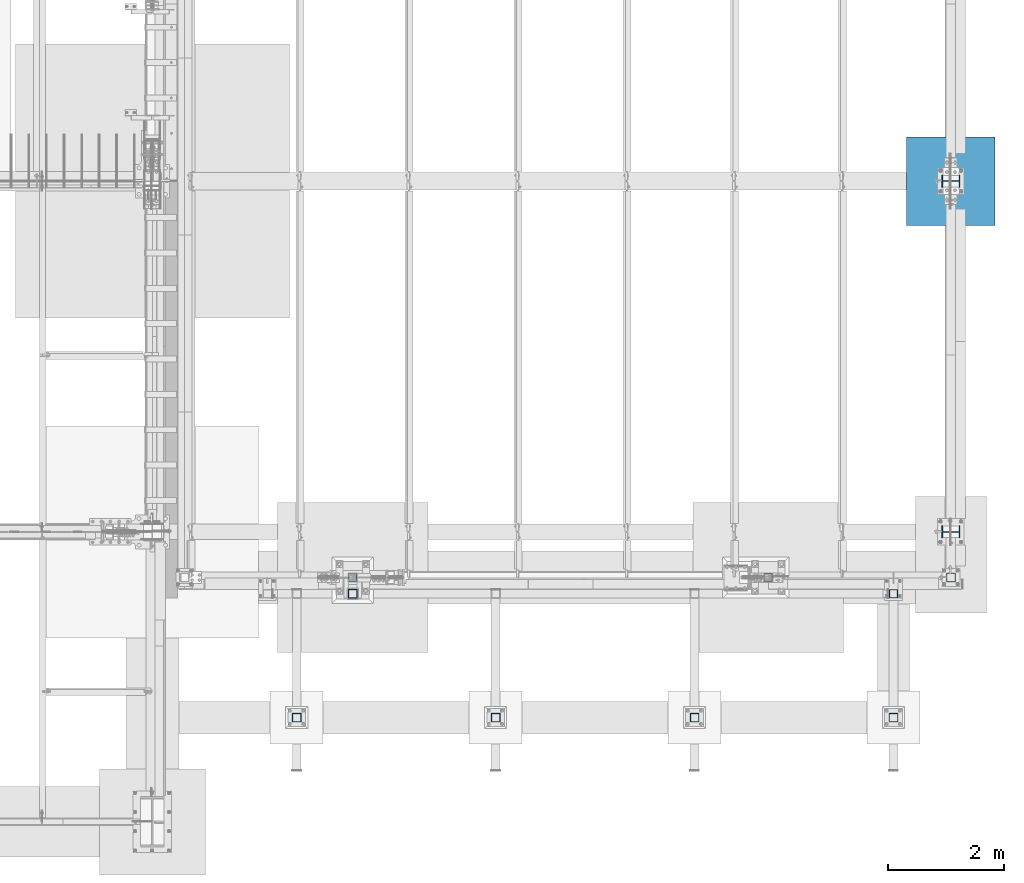
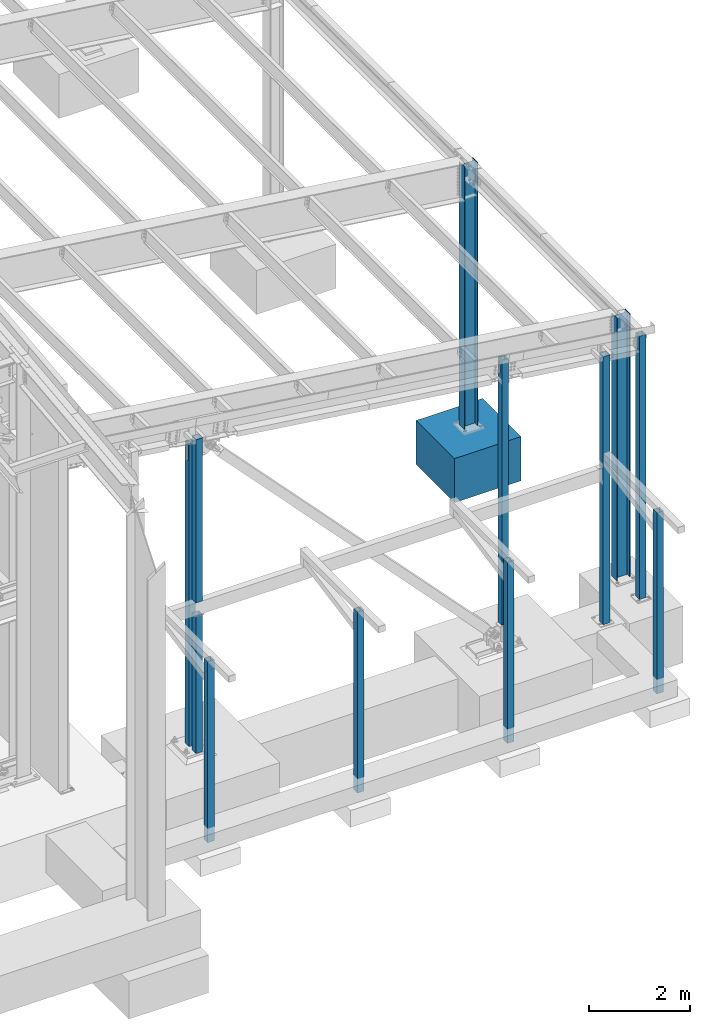
# One storey, part 360 of 1179: 13 columns, 13 elements without a shape of their own.
"""IFC2X3 building model written with IfcOpenShell, lengths in millimetres."""

from ifc_helpers import new_model, si_unit, frame, origin_with_axes, place, context, subcontext, project, spatial, faceted_brep, material, type_object, element, aggregate, save


model = new_model("IFC2X3")

# Units and contexts
model_context = context("Model", 3, precision=1e-05, world=origin_with_axes())
body_context = subcontext(model_context, "Body", "Model", "MODEL_VIEW")
ifc_project = project(units=[si_unit("LENGTHUNIT", "METRE", prefix="MILLI"), si_unit("AREAUNIT", "SQUARE_METRE"), si_unit("VOLUMEUNIT", "CUBIC_METRE"), si_unit("MASSUNIT", "GRAM", prefix="KILO"), si_unit("TIMEUNIT", "SECOND"), si_unit("PLANEANGLEUNIT", "RADIAN"), si_unit("SOLIDANGLEUNIT", "STERADIAN"), si_unit("THERMODYNAMICTEMPERATUREUNIT", "DEGREE_CELSIUS"), si_unit("LUMINOUSINTENSITYUNIT", "LUMEN")], contexts=[model_context])

# Site, building, storey
site_placement = place(None, origin_with_axes())
site = spatial("IfcSite", under=ifc_project, at=site_placement, CompositionType="ELEMENT")
building_placement = place(site_placement, origin_with_axes())
building = spatial("IfcBuilding", under=site, at=building_placement, Name="Undefined", CompositionType="ELEMENT")
storey_placement = place(building_placement, origin_with_axes())
storey = spatial("IfcBuildingStorey", under=building, at=storey_placement, Name="Undefined", CompositionType="ELEMENT", Elevation=0.0)

# Assembly, column
assembly_1_placement = place(storey_placement, origin_with_axes())
assembly_1 = element("IfcElementAssembly", 1, at=assembly_1_placement, inside=storey, Name="COLUMN", AssemblyPlace="NOTDEFINED", PredefinedType="RIGID_FRAME")
ifc_material_1 = material()
column_type_1 = type_object("IfcColumnType", Name="HSS6X6X3/8", PredefinedType="NOTDEFINED")
column_1_placement = place(assembly_1_placement, frame((38074.6, 4648.2, -355.599999999999), z_axis=(0.0, 1.0, 0.0), x_axis=(0.0, 0.0, 1.0)))
column_1 = element("IfcColumn", 2, at=column_1_placement, type_object=column_type_1, material=ifc_material_1, Name="COLUMN", ObjectType="HSS6X6X3/8", context=body_context, shape_type="Brep", body=[
    faceted_brep([(76.2000000000008, 66.675000000112, -66.6749999999902), (76.2000000000008, -66.6750000001084, -66.6750000000175), (6446.8375, -66.6750000000029, -66.6750000000002), (6446.8375, 66.6750000000029, -66.6750000000002), (76.2000000000008, -66.6750000001011, 66.674999999992), (6446.8375, -66.6750000000029, 66.6750000000002), (76.2000000000008, 66.6750000001193, 66.6750000000193), (6446.8375, 66.6750000000029, 66.6750000000002), (76.2000000000008, 76.2000000001281, -76.1999999999898), (76.2000000000008, 76.2000000001317, 76.2000000000216), (6446.8375, 76.1999999999971, 76.1999999999998), (6446.8375, 76.1999999999971, -76.1999999999998), (76.2000000000008, -76.2000000001171, 76.1999999999916), (6446.8375, -76.1999999999971, 76.1999999999998), (76.2000000000008, -76.2000000001208, -76.2000000000198), (6446.8375, -76.1999999999971, -76.1999999999998)], [[[0, 1, 2, 3]], [[1, 4, 5, 2]], [[4, 6, 7, 5]], [[6, 0, 3, 7]], [[8, 9, 10, 11]], [[9, 12, 13, 10]], [[12, 14, 15, 13]], [[14, 8, 11, 15]], [[13, 15, 11, 10], [5, 7, 3, 2]], [[14, 12, 9, 8], [6, 4, 1, 0]]]),
])
aggregate(assembly_1, [column_1])

assembly_2_placement = place(storey_placement, origin_with_axes())
assembly_2 = element("IfcElementAssembly", 3, at=assembly_2_placement, inside=storey, Name="COLUMN", AssemblyPlace="NOTDEFINED", PredefinedType="RIGID_FRAME")
column_type_2 = type_object("IfcColumnType", Name="HSS6X6X5/8", PredefinedType="NOTDEFINED")
column_2_placement = place(assembly_2_placement, frame((34925.0, 4648.2, 495.299974039363), z_axis=(0.0, 1.0, 0.0), x_axis=(0.0, 0.0, 1.0)))
column_2 = element("IfcColumn", 4, at=column_2_placement, type_object=column_type_2, material=ifc_material_1, Name="COLUMN", ObjectType="HSS6X6X5/8", context=body_context, shape_type="Brep", body=[
    faceted_brep([(5747.63958632009, -76.2000000000407, 5.85754753591027), (5747.60831617678, -76.2000000000407, -3.82465809047153), (5747.63958632009, -60.3249999999971, 5.85754753591027), (6052.92287423471, -60.3249999999971, 5.55625000000236), (5749.15431132124, -60.3249999999971, 5.55625000000236), (6053.99631617678, -76.2000000000407, -3.82465809047153), (6053.98303151881, -60.3249999999971, 5.76712839517677), (6053.99631617678, -76.2000000000407, 5.70034190952811), (6118.01037424087, -76.1999999999971, 76.1999999999998), (6097.4321702663, 76.1999999999971, 76.1999999999998), (-297.364801174595, 76.1999999999971, 76.1999999999998), (-297.364801177734, -76.2000000009066, 76.2000000009066), (-306.53024097503, 60.3249999999971, 60.3249999999998), (-306.53024097503, -60.3249999999971, 60.3249999999998), (6099.57573318032, 60.3249999999971, 60.3249999999998), (6115.86681132685, -60.3249999999971, 60.3249999999998), (6115.86681132685, -60.3249999999971, -60.3249999999998), (6099.57573318032, 60.3249999999971, -60.3249999999998), (-306.53024097503, 60.3249999999971, -60.3249999999998), (-306.53024097503, -60.3249999999971, -60.3249999999998), (6118.01037424087, -76.1999999999971, -76.1999999999998), (6097.4321702663, 76.1999999999971, -76.1999999999998), (-297.364801178257, -76.1999999999971, -76.1999999999998), (-297.364801178257, 76.1999999999971, -76.1999999999998), (5727.68212052118, 76.1999999999971, 6.16045621069406), (5727.68212052118, 60.3249999999971, 6.16045621069406), (5729.99527131832, 60.3249999999971, 5.70034190952811), (5729.99527131832, 76.1999999999971, 5.70034190952811), (5725.10701018991, 76.1999999999971, 7.88108992433445), (5725.10701018991, 60.3249999999971, 7.88108992433445), (5723.38637647627, 76.1999999999971, 10.456200255604), (5723.38637647627, 60.3249999999971, 10.456200255604), (5722.78217026557, 76.1999999999971, 13.4937500000024), (5722.78217026557, 60.3249999999971, 13.4937500000024), (5722.78217026557, 76.1999999999971, 26.1937500000031), (5722.78217026557, 60.3249999999971, 26.1937500000031), (5723.38637647627, 76.1999999999971, 29.2312997444014), (5723.38637647627, 60.3249999999971, 29.2312997444014), (5725.10701018991, 76.1999999999971, 31.806410075671), (5725.10701018991, 60.3249999999971, 31.806410075671), (5727.68212052118, 76.1999999999971, 33.5270437893114), (5727.68212052118, 60.3249999999971, 33.5270437893114), (5729.72700903751, 76.1999999999971, 33.9337974051232), (5729.72700903751, 60.3249999999971, 33.9337974051232), (5729.72700903751, 76.2000000001353, 43.0992329262926), (6036.11500903751, 76.2000000001353, 43.0992329262926), (6036.09087448646, 60.3249999999971, 33.8124648234862), (6034.48823317905, 60.3249999999971, 34.1312500000031), (5730.71967026557, 60.3249999999971, 34.1312500000031), (6036.09087448646, 76.1999999999971, 33.8124648234862), (6037.52578292345, 76.1999999999971, 33.5270437893114), (6037.52578292345, 60.3249999999971, 33.5270437893114), (6040.10089325472, 76.1999999999971, 31.806410075671), (6040.10089325472, 60.3249999999971, 31.806410075671), (6041.82152696836, 76.1999999999971, 29.2312997444014), (6041.82152696836, 60.3249999999971, 29.2312997444014), (6042.42573317905, 76.1999999999971, 26.1937500000031), (6042.42573317905, 60.3249999999971, 26.1937500000031), (6042.42573317905, 76.1999999999971, 13.4937500000024), (6042.42573317905, 60.3249999999971, 13.4937500000024), (6041.82152696836, 76.1999999999971, 10.456200255604), (6041.82152696836, 60.3249999999971, 10.456200255604), (6040.10089325472, 76.1999999999971, 7.88108992433445), (6040.10089325472, 60.3249999999971, 7.88108992433445), (6037.52578292345, 76.1999999999971, 6.16045621069406), (6037.52578292345, 60.3249999999971, 6.16045621069406), (6036.33871651704, 76.1999999999971, 5.92433402155893), (6036.38327131832, 60.3249999999971, 5.70034190952811), (6036.38327131832, 76.1999999999971, -3.82465809047153), (5729.99527131832, 76.1999999999971, -3.82465809047153), (5730.71967026557, 60.3249999999971, 5.55625000000236), (6034.48823317905, 60.3249999999971, 5.55625000000236), (5746.11676157684, -76.200000000048, 6.16045621069406), (5746.11676157684, -60.3249999999971, 6.16045621069406), (5743.54165124557, -60.3249999999971, 7.88108992433445), (5743.54165124557, -76.200000000048, 7.88108992433445), (5741.82101753193, -60.3249999999971, 10.456200255604), (5741.82101753193, -76.2000000000553, 10.456200255604), (5741.21681132124, -60.3249999999971, 13.4937500000024), (5741.21681132124, -76.2000000000698, 13.4937500000024), (5741.21681132124, -60.3249999999971, 26.1937500000031), (5741.21681132124, -76.2000000001062, 26.1937500000031), (5741.82101753193, -60.3249999999971, 29.2312997444014), (5741.82101753193, -76.2000000001135, 29.2312997444014), (5743.54165124557, -60.3249999999971, 31.806410075671), (5743.54165124557, -76.2000000001208, 31.806410075671), (5746.11676157684, -60.3249999999971, 33.5270437893114), (5746.11676157684, -76.2000000001281, 33.5270437893114), (5747.5894509322, -60.3249999999971, 33.8199799154008), (5747.5894509322, -76.2000000001281, 33.8199799154008), (5747.56681122587, -76.2000000001208, 43.0992329262926), (5749.15431132124, -60.3249999999971, 34.1312500000031), (6052.92287423471, -60.3249999999971, 34.1312500000031), (6053.95331638115, -60.3249999999971, 33.9262823132085), (6053.95481122587, -76.2000000001208, 43.0992329262926), (6053.95331638115, -76.2000000001062, 33.9262823132085), (6055.96042397911, -60.3249999999971, 33.5270437893114), (6055.96042397911, -76.2000000001062, 33.5270437893114), (6058.53553431038, -60.3249999999971, 31.806410075671), (6058.53553431038, -76.200000000099, 31.806410075671), (6060.25616802402, -60.3249999999971, 29.2312997444014), (6060.25616802402, -76.2000000000917, 29.2312997444014), (6060.86037423471, -60.3249999999971, 26.1937500000031), (6060.86037423471, -76.2000000000844, 26.1937500000031), (6060.86037423471, -60.3249999999971, 13.4937500000024), (6060.86037423471, -76.2000000000407, 13.4937500000024), (6060.25616802402, -60.3249999999971, 10.456200255604), (6060.25616802402, -76.2000000000335, 10.456200255604), (6058.53553431038, -60.3249999999971, 7.88108992433445), (6058.53553431038, -76.2000000000262, 7.88108992433445), (6055.96042397911, -60.3249999999971, 6.16045621069406), (6055.96042397911, -76.2000000000262, 6.16045621069406)], [[[0, 1, 2]], [[3, 4, 2, 1, 5, 6]], [[7, 6, 5]], [[8, 9, 10, 11]], [[10, 12, 13, 11]], [[14, 15, 13, 12]], [[16, 17, 18, 19]], [[8, 20, 21, 9], [15, 14, 17, 16]], [[21, 20, 22, 23]], [[24, 25, 26, 27]], [[25, 24, 28, 29]], [[29, 28, 30, 31]], [[31, 30, 32, 33]], [[33, 32, 34, 35]], [[35, 34, 36, 37]], [[37, 36, 38, 39]], [[39, 38, 40, 41]], [[41, 40, 42, 43]], [[44, 43, 42]], [[45, 46, 47, 48, 43, 44]], [[49, 46, 45]], [[50, 51, 46, 49]], [[51, 50, 52, 53]], [[53, 52, 54, 55]], [[55, 54, 56, 57]], [[57, 56, 58, 59]], [[59, 58, 60, 61]], [[61, 60, 62, 63]], [[63, 62, 64, 65]], [[65, 64, 66, 67]], [[66, 68, 67]], [[9, 21, 23, 10], [64, 62, 60, 58, 56, 54, 52, 50, 49, 45, 44, 42, 40, 38, 36, 34, 32, 30, 28, 24, 27, 69, 68, 66]], [[26, 69, 27]], [[67, 68, 69, 26, 70, 71]], [[17, 14, 12, 18], [70, 26, 25, 29, 31, 33, 35, 37, 39, 41, 43, 48, 47, 46, 51, 53, 55, 57, 59, 61, 63, 65, 67, 71]], [[10, 23, 18, 12]], [[22, 19, 18, 23]], [[11, 13, 19, 22]], [[72, 73, 74, 75]], [[75, 74, 76, 77]], [[77, 76, 78, 79]], [[79, 78, 80, 81]], [[81, 80, 82, 83]], [[83, 82, 84, 85]], [[85, 84, 86, 87]], [[87, 86, 88, 89]], [[89, 88, 90]], [[90, 88, 91, 92, 93, 94]], [[94, 93, 95]], [[96, 97, 95, 93]], [[97, 96, 98, 99]], [[99, 98, 100, 101]], [[101, 100, 102, 103]], [[103, 102, 104, 105]], [[105, 104, 106, 107]], [[107, 106, 108, 109]], [[109, 108, 110, 111]], [[20, 8, 11, 22], [1, 0, 72, 75, 77, 79, 81, 83, 85, 87, 89, 90, 94, 95, 97, 99, 101, 103, 105, 107, 109, 111, 7, 5]], [[73, 72, 0, 2]], [[15, 16, 19, 13], [110, 108, 106, 104, 102, 100, 98, 96, 93, 92, 91, 88, 86, 84, 82, 80, 78, 76, 74, 73, 2, 4, 3, 6]], [[111, 110, 6, 7]]]),
])
aggregate(assembly_2, [column_2])

assembly_3_placement = place(storey_placement, origin_with_axes())
assembly_3 = element("IfcElementAssembly", 5, at=assembly_3_placement, inside=storey, Name="COLUMN", AssemblyPlace="NOTDEFINED", PredefinedType="RIGID_FRAME")
column_3_placement = place(assembly_3_placement, frame((27762.2, 4648.2, -355.599999999999), z_axis=(0.0, 1.0, 0.0), x_axis=(0.0, 0.0, 1.0)))
column_3 = element("IfcColumn", 6, at=column_3_placement, type_object=column_type_2, material=ifc_material_1, Name="COLUMN", ObjectType="HSS6X6X5/8", context=body_context, shape_type="Brep", body=[
    faceted_brep([(7017.90605595571, -76.2000000000007, 19.0500000000029), (7017.90605595571, -60.3250000000007, 19.0500000000029), (7017.90605595571, -76.2000000000007, 28.215435902579), (7453.45682125332, -60.3250000000044, 19.0500003814714), (7446.45897397895, -76.2000000000007, 28.215435902579), (127.0, -76.2000000000007, -76.1999999999998), (127.0, 76.2000000000007, -76.1999999999998), (7425.89405519277, 76.2000000000007, -76.1999999999998), (7446.38942084956, -76.2000000000007, -76.1999999999998), (7425.89405519277, 76.2000000000007, 76.1999999999998), (7437.16574310679, 60.3250000000007, 60.3249999999998), (7437.16574310679, 60.3250000000116, 19.0500000000029), (7425.89405519277, 76.2000000000007, 28.2154355211105), (127.0, 60.3250000000007, 60.3249999999998), (127.0, 60.3250000000007, -60.3249999999998), (7437.16574310679, 60.3250000000007, -60.3249999999998), (7437.14646512411, 60.3250000000116, -19.0499999999956), (7017.90605477555, 60.3251050701656, -19.0499999999956), (7017.59729324514, 60.3250000000007, -19.0499999999956), (7013.95223369785, 60.3250000000007, -18.324952576203), (7010.86210142408, 60.3250000000007, -16.2601922025278), (7008.79734105041, 60.3250000000007, -13.1700599287606), (7008.07229362661, 60.3250000000007, -9.52500038146536), (7008.07229362661, 60.3250000000007, 9.52500038147264), (7008.79734105041, 60.3250000000007, 13.1700599287678), (7010.86210142408, 60.3250000000007, 16.2601922025351), (7013.95223369785, 60.3250000000007, 18.3249525762103), (7017.59729324514, 60.3250000000007, 19.0500000000029), (7017.9060548113, 60.3250000000007, 19.0500000000029), (7017.59729324514, 76.2000000000007, -19.0499999999956), (7017.9060548113, 76.2000000000007, -19.0499999999956), (7013.95223369785, 76.2000000000007, -18.324952576203), (7010.86210142408, 76.2000000000007, -16.2601922025278), (7008.79734105041, 76.2000000000007, -13.1700599287606), (7008.07229362661, 76.2000000000007, -9.52500038146536), (7008.07229362661, 76.2000000000007, 9.52500038147264), (7008.79734105041, 76.2000000000007, 13.1700599287678), (7010.86210142408, 76.2000000000007, 16.2601922025351), (7013.95223369785, 76.2000000000007, 18.3249525762103), (7017.59729324514, 76.2000000000007, 19.0500000000029), (7017.9060548113, 76.2000000000007, 19.0500000000029), (7017.9060548113, 76.200000000008, 28.2154355211105), (7017.9060548113, 76.200000000008, -28.2154355211032), (7425.89405519277, 76.2000000000007, -28.2154355211032), (127.0, 76.2000000000007, 76.1999999999998), (7013.95223369785, -76.2000000000007, 18.3249525762103), (7013.95223369785, -60.3250000000007, 18.3249525762103), (7017.59729324514, -60.3250000000007, 19.0500000000029), (7017.59729324514, -76.2000000000007, 19.0500000000029), (7010.86210142408, -76.2000000000007, 16.2601922025351), (7010.86210142408, -60.3250000000007, 16.2601922025351), (7008.79734105041, -76.2000000000007, 13.1700599287678), (7008.79734105041, -60.3250000000007, 13.1700599287678), (7008.07229362661, -76.2000000000007, 9.52500038147264), (7008.07229362661, -60.3250000000007, 9.52500038147264), (7008.07229362661, -76.2000000000007, -9.52500038146536), (7008.07229362661, -60.3250000000007, -9.52500038146536), (7008.79734105041, -76.2000000000007, -13.1700599287606), (7008.79734105041, -60.3250000000007, -13.1700599287606), (7010.86210142408, -76.2000000000007, -16.2601922025278), (7010.86210142408, -60.3250000000007, -16.2601922025278), (7013.95223369785, -76.2000000000007, -18.324952576203), (7013.95223369785, -60.3250000000007, -18.324952576203), (7017.59729324514, -76.2000000000007, -19.0499999999956), (7017.59729324514, -60.3250000000007, -19.0499999999956), (7017.90605595571, -76.2000000000007, -19.0499999999956), (7017.90605592259, -60.3251011342254, -19.0499999999956), (7017.90605595571, -76.2000000000007, -28.2154359025726), (7453.47609923807, -60.3250000000044, -19.050000381465), (7446.45897396538, -76.2000000000007, -28.2154359025726), (7453.45682125332, -60.3250000000007, -60.3249999999998), (127.0, -60.3250000000007, -60.3249999999998), (127.0, -76.2000000000007, 76.1999999999998), (127.0, -60.3250000000007, 60.3249999999998), (7446.38942093416, -76.2000000000007, 76.1999999999998), (7453.47609923807, -60.4677707066257, 60.3249999999998)], [[[0, 1, 2]], [[3, 4, 2, 1]], [[5, 6, 7, 8]], [[9, 10, 11, 12]], [[10, 13, 14, 15, 16, 17, 18, 19, 20, 21, 22, 23, 24, 25, 26, 27, 28, 11]], [[29, 18, 17, 30]], [[18, 29, 31, 19]], [[19, 31, 32, 20]], [[20, 32, 33, 21]], [[21, 33, 34, 22]], [[22, 34, 35, 23]], [[23, 35, 36, 24]], [[24, 36, 37, 25]], [[25, 37, 38, 26]], [[26, 38, 39, 27]], [[27, 39, 40, 28]], [[41, 28, 40]], [[11, 28, 41, 12]], [[40, 39, 38, 37, 36, 35, 34, 33, 32, 31, 29, 30, 42, 43, 7, 6, 44, 9, 12, 41]], [[17, 42, 30]], [[16, 43, 42, 17]], [[15, 7, 43, 16]], [[45, 46, 47, 48]], [[49, 50, 46, 45]], [[51, 52, 50, 49]], [[53, 54, 52, 51]], [[55, 56, 54, 53]], [[57, 58, 56, 55]], [[59, 60, 58, 57]], [[61, 62, 60, 59]], [[63, 64, 62, 61]], [[64, 63, 65, 66]], [[65, 67, 66]], [[68, 66, 67, 69]], [[8, 70, 68, 69]], [[7, 15, 70, 8]], [[14, 71, 70, 15]], [[5, 72, 44, 6], [13, 73, 71, 14]], [[44, 72, 74, 9]], [[10, 9, 74, 75]], [[73, 13, 10, 75]], [[47, 46, 50, 52, 54, 56, 58, 60, 62, 64, 66, 68, 70, 71, 73, 75, 3, 1]], [[48, 47, 1, 0]], [[74, 72, 5, 8, 69, 67, 65, 63, 61, 59, 57, 55, 53, 51, 49, 45, 48, 0, 2, 4]], [[75, 74, 4, 3]]]),
])
aggregate(assembly_3, [column_3])

assembly_4_placement = place(storey_placement, origin_with_axes())
assembly_4 = element("IfcElementAssembly", 7, at=assembly_4_placement, inside=storey, Name="COLUMN", AssemblyPlace="NOTDEFINED", PredefinedType="RIGID_FRAME")
column_type_3 = type_object("IfcColumnType", Name="HSS6X6X1/4", PredefinedType="NOTDEFINED")
column_4_placement = place(assembly_4_placement, frame((27762.2, 4368.8, 3416.3), z_axis=(0.0, 1.0, 0.0), x_axis=(0.0, 0.0, 1.0)))
column_4 = element("IfcColumn", 8, at=column_4_placement, type_object=column_type_3, material=ifc_material_1, Name="COLUMN", ObjectType="HSS6X6X1/4", context=body_context, shape_type="Brep", body=[
    faceted_brep([(0.0, 69.8499999999985, -69.8499999999985), (0.0, -69.8499999999985, -69.8499999999985), (3951.22380466022, -69.8499999999985, -69.8500000000004), (3951.22380466022, 69.8499999999985, -69.8500000000004), (0.0, -69.8499999983651, 69.849999997823), (3951.22380466022, -69.8499999999985, 69.8500000000004), (0.0, 69.8499999983651, 69.849999997823), (3951.22380466022, 69.8499999999985, 69.8500000000004), (6.54836185276508e-11, 76.2, -76.1999999999998), (6.54836185276508e-11, 76.2, 76.1999999999998), (3951.22380466022, 76.2000000000007, 76.1999999999998), (3951.22380466022, 76.2000000000007, -76.1999999999998), (-6.54836185276508e-11, -76.2, 76.1999999999998), (3951.22380466022, -76.2000000000007, 76.1999999999998), (-6.54836185276508e-11, -76.2, -76.1999999999998), (3951.22380466022, -76.2000000000007, -76.1999999999998)], [[[0, 1, 2, 3]], [[1, 4, 5, 2]], [[4, 6, 7, 5]], [[6, 0, 3, 7]], [[8, 9, 10, 11]], [[9, 12, 13, 10]], [[12, 14, 15, 13]], [[14, 8, 11, 15]], [[13, 15, 11, 10], [5, 7, 3, 2]], [[14, 12, 9, 8], [6, 4, 1, 0]]]),
])
aggregate(assembly_4, [column_4])

assembly_5_placement = place(storey_placement, origin_with_axes())
assembly_5 = element("IfcElementAssembly", 9, at=assembly_5_placement, inside=storey, Name="COLUMN", AssemblyPlace="NOTDEFINED", PredefinedType="RIGID_FRAME")
column_5_placement = place(assembly_5_placement, frame((27762.2, 4368.8, -228.6), z_axis=(0.0, 1.0, 0.0), x_axis=(0.0, 0.0, 1.0)))
column_5 = element("IfcColumn", 10, at=column_5_placement, type_object=column_type_3, material=ifc_material_1, Name="COLUMN", ObjectType="HSS6X6X1/4", context=body_context, shape_type="Brep", body=[
    faceted_brep([(0.0, 69.8499999999985, -69.8499999999985), (0.0, -69.8499999999985, -69.8499999999985), (3321.05, -69.8499999999985, -69.8500000000004), (3321.05, 69.8499999999985, -69.8500000000004), (0.0, -69.8499999983651, 69.849999997823), (3321.05, -69.8499999999985, 69.8500000000004), (0.0, 69.8499999983651, 69.849999997823), (3321.05, 69.8499999999985, 69.8500000000004), (6.54836185276508e-11, 76.2, -76.1999999999998), (6.54836185276508e-11, 76.2, 76.1999999999998), (3321.05, 76.2000000000007, 76.1999999999998), (3321.05, 76.2000000000007, -76.1999999999998), (-6.54836185276508e-11, -76.2, 76.1999999999998), (3321.05, -76.2000000000007, 76.1999999999998), (-6.54836185276508e-11, -76.2, -76.1999999999998), (3321.05, -76.2000000000007, -76.1999999999998)], [[[0, 1, 2, 3]], [[1, 4, 5, 2]], [[4, 6, 7, 5]], [[6, 0, 3, 7]], [[8, 9, 10, 11]], [[9, 12, 13, 10]], [[12, 14, 15, 13]], [[14, 8, 11, 15]], [[13, 15, 11, 10], [5, 7, 3, 2]], [[14, 12, 9, 8], [6, 4, 1, 0]]]),
])
aggregate(assembly_5, [column_5])

assembly_6_placement = place(storey_placement, origin_with_axes())
assembly_6 = element("IfcElementAssembly", 11, at=assembly_6_placement, inside=storey, Name="COLUMN", AssemblyPlace="NOTDEFINED", PredefinedType="RIGID_FRAME")
column_6_placement = place(assembly_6_placement, frame((26797.0, 2235.2, -812.8), z_axis=(0.0, 1.0, 0.0), x_axis=(0.0, 0.0, 1.0)))
column_6 = element("IfcColumn", 12, at=column_6_placement, type_object=column_type_3, material=ifc_material_1, Name="COLUMN", ObjectType="HSS6X6X1/4", context=body_context, shape_type="Brep", body=[
    faceted_brep([(57.15, 69.8499999999804, -69.8499999999957), (57.15, -69.8500000000104, -69.8499999999983), (4438.65, -69.8499999999985, -69.8499999999999), (4438.65, 69.8499999999985, -69.8499999999999), (57.15, -69.8499999999808, 69.8499999999956), (4438.65, -69.8499999999985, 69.8499999999999), (57.15, 69.8500000000104, 69.8499999999981), (4438.65, 69.8499999999985, 69.8499999999999), (57.15, 76.1999999999789, -76.1999999999953), (57.15, 76.2000000000112, 76.1999999999979), (4438.65, 76.2000000000007, 76.1999999999998), (4438.65, 76.2000000000007, -76.1999999999998), (57.15, -76.1999999999789, 76.1999999999952), (4438.65, -76.2000000000007, 76.1999999999998), (57.15, -76.2000000000116, -76.199999999998), (4438.65, -76.2000000000007, -76.1999999999998)], [[[0, 1, 2, 3]], [[1, 4, 5, 2]], [[4, 6, 7, 5]], [[6, 0, 3, 7]], [[8, 9, 10, 11]], [[9, 12, 13, 10]], [[12, 14, 15, 13]], [[14, 8, 11, 15]], [[13, 15, 11, 10], [5, 7, 3, 2]], [[14, 12, 9, 8], [6, 4, 1, 0]]]),
])
aggregate(assembly_6, [column_6])

assembly_7_placement = place(storey_placement, origin_with_axes())
assembly_7 = element("IfcElementAssembly", 13, at=assembly_7_placement, inside=storey, Name="COLUMN", AssemblyPlace="NOTDEFINED", PredefinedType="RIGID_FRAME")
column_7_placement = place(assembly_7_placement, frame((30226.0, 2235.2, -812.8), z_axis=(0.0, 1.0, 0.0), x_axis=(0.0, 0.0, 1.0)))
column_7 = element("IfcColumn", 14, at=column_7_placement, type_object=column_type_3, material=ifc_material_1, Name="COLUMN", ObjectType="HSS6X6X1/4", context=body_context, shape_type="Brep", body=[
    faceted_brep([(57.15, 69.8499999999804, -69.8499999999957), (57.15, -69.8500000000104, -69.8499999999983), (4438.65, -69.8499999999985, -69.8499999999999), (4438.65, 69.8499999999985, -69.8499999999999), (57.15, -69.8499999999808, 69.8499999999956), (4438.65, -69.8499999999985, 69.8499999999999), (57.15, 69.8500000000104, 69.8499999999981), (4438.65, 69.8499999999985, 69.8499999999999), (57.15, 76.1999999999789, -76.1999999999953), (57.15, 76.2000000000112, 76.1999999999979), (4438.65, 76.2000000000007, 76.1999999999998), (4438.65, 76.2000000000007, -76.1999999999998), (57.15, -76.1999999999789, 76.1999999999952), (4438.65, -76.2000000000007, 76.1999999999998), (57.15, -76.2000000000116, -76.199999999998), (4438.65, -76.2000000000007, -76.1999999999998)], [[[0, 1, 2, 3]], [[1, 4, 5, 2]], [[4, 6, 7, 5]], [[6, 0, 3, 7]], [[8, 9, 10, 11]], [[9, 12, 13, 10]], [[12, 14, 15, 13]], [[14, 8, 11, 15]], [[13, 15, 11, 10], [5, 7, 3, 2]], [[14, 12, 9, 8], [6, 4, 1, 0]]]),
])
aggregate(assembly_7, [column_7])

assembly_8_placement = place(storey_placement, origin_with_axes())
assembly_8 = element("IfcElementAssembly", 15, at=assembly_8_placement, inside=storey, Name="COLUMN", AssemblyPlace="NOTDEFINED", PredefinedType="RIGID_FRAME")
column_8_placement = place(assembly_8_placement, frame((33655.0, 2235.2, -812.8), z_axis=(0.0, 1.0, 0.0), x_axis=(0.0, 0.0, 1.0)))
column_8 = element("IfcColumn", 16, at=column_8_placement, type_object=column_type_3, material=ifc_material_1, Name="COLUMN", ObjectType="HSS6X6X1/4", context=body_context, shape_type="Brep", body=[
    faceted_brep([(57.15, 69.8499999999804, -69.8499999999957), (57.15, -69.8500000000104, -69.8499999999983), (4438.65, -69.8499999999985, -69.8499999999999), (4438.65, 69.8499999999985, -69.8499999999999), (57.15, -69.8499999999808, 69.8499999999956), (4438.65, -69.8499999999985, 69.8499999999999), (57.15, 69.8500000000104, 69.8499999999981), (4438.65, 69.8499999999985, 69.8499999999999), (57.15, 76.1999999999789, -76.1999999999953), (57.15, 76.2000000000112, 76.1999999999979), (4438.65, 76.2000000000007, 76.1999999999998), (4438.65, 76.2000000000007, -76.1999999999998), (57.15, -76.1999999999789, 76.1999999999952), (4438.65, -76.2000000000007, 76.1999999999998), (57.15, -76.2000000000116, -76.199999999998), (4438.65, -76.2000000000007, -76.1999999999998)], [[[0, 1, 2, 3]], [[1, 4, 5, 2]], [[4, 6, 7, 5]], [[6, 0, 3, 7]], [[8, 9, 10, 11]], [[9, 12, 13, 10]], [[12, 14, 15, 13]], [[14, 8, 11, 15]], [[13, 15, 11, 10], [5, 7, 3, 2]], [[14, 12, 9, 8], [6, 4, 1, 0]]]),
])
aggregate(assembly_8, [column_8])

assembly_9_placement = place(storey_placement, origin_with_axes())
assembly_9 = element("IfcElementAssembly", 17, at=assembly_9_placement, inside=storey, Name="COLUMN", AssemblyPlace="NOTDEFINED", PredefinedType="RIGID_FRAME")
column_9_placement = place(assembly_9_placement, frame((37084.0, 2235.2, -812.8), z_axis=(0.0, 1.0, 0.0), x_axis=(0.0, 0.0, 1.0)))
column_9 = element("IfcColumn", 18, at=column_9_placement, type_object=column_type_3, material=ifc_material_1, Name="COLUMN", ObjectType="HSS6X6X1/4", context=body_context, shape_type="Brep", body=[
    faceted_brep([(57.15, 69.8499999999804, -69.8499999999957), (57.15, -69.8500000000104, -69.8499999999983), (4438.65, -69.8499999999985, -69.8499999999999), (4438.65, 69.8499999999985, -69.8499999999999), (57.15, -69.8499999999808, 69.8499999999956), (4438.65, -69.8499999999985, 69.8499999999999), (57.15, 69.8500000000104, 69.8499999999981), (4438.65, 69.8499999999985, 69.8499999999999), (57.15, 76.1999999999789, -76.1999999999953), (57.15, 76.2000000000112, 76.1999999999979), (4438.65, 76.2000000000007, 76.1999999999998), (4438.65, 76.2000000000007, -76.1999999999998), (57.15, -76.1999999999789, 76.1999999999952), (4438.65, -76.2000000000007, 76.1999999999998), (57.15, -76.2000000000116, -76.199999999998), (4438.65, -76.2000000000007, -76.1999999999998)], [[[0, 1, 2, 3]], [[1, 4, 5, 2]], [[4, 6, 7, 5]], [[6, 0, 3, 7]], [[8, 9, 10, 11]], [[9, 12, 13, 10]], [[12, 14, 15, 13]], [[14, 8, 11, 15]], [[13, 15, 11, 10], [5, 7, 3, 2]], [[14, 12, 9, 8], [6, 4, 1, 0]]]),
])
aggregate(assembly_9, [column_9])

assembly_10_placement = place(storey_placement, origin_with_axes())
assembly_10 = element("IfcElementAssembly", 19, at=assembly_10_placement, inside=storey, Name="FOOTING", AssemblyPlace="NOTDEFINED", PredefinedType="REINFORCEMENT_UNIT")
ifc_material_2 = material(Name="CONCRETE/3000")
column_type_4 = type_object("IfcColumnType", PredefinedType="NOTDEFINED")
column_10_placement = place(assembly_10_placement, frame((38074.6, 11480.8, -1422.4), z_axis=(-1.0, 0.0, 0.0), x_axis=(0.0, 0.0, 1.0)))
column_10 = element("IfcColumn", 20, at=column_10_placement, type_object=column_type_4, material=ifc_material_2, Name="FOOTING", context=body_context, shape_type="Brep", body=[
    faceted_brep([(0.0, 761.999999999822, -761.999999999945), (0.0, 761.999999999945, 761.99999999982), (1066.8, 762.0, 762.0), (1066.8, 762.0, -762.0), (0.0, -761.999999999821, 761.999999999942), (1066.8, -762.0, 762.0), (0.0, -761.999999999944, -761.999999999822), (1066.8, -762.0, -762.0)], [[[0, 1, 2, 3]], [[1, 4, 5, 2]], [[4, 6, 7, 5]], [[6, 0, 3, 7]], [[5, 7, 3, 2]], [[6, 4, 1, 0]]]),
])
aggregate(assembly_10, [column_10])

assembly_11_placement = place(storey_placement, origin_with_axes())
assembly_11 = element("IfcElementAssembly", 21, at=assembly_11_placement, inside=storey, Name="COLUMN", AssemblyPlace="NOTDEFINED", PredefinedType="RIGID_FRAME")
column_type_5 = type_object("IfcColumnType", Name="HSS6X6X1/2", PredefinedType="NOTDEFINED")
column_11_placement = place(assembly_11_placement, frame((37084.0, 4368.8, -431.8), z_axis=(0.0, 1.0, 0.0), x_axis=(0.0, 0.0, 1.0)))
column_11 = element("IfcColumn", 22, at=column_11_placement, type_object=column_type_5, material=ifc_material_1, Name="COLUMN", ObjectType="HSS6X6X1/2", context=body_context, shape_type="Brep", body=[
    faceted_brep([(57.15, 63.5, -63.5), (57.15, -63.5, -63.5), (6540.09668998843, -63.5, -63.5), (6540.09668998843, 63.5, -63.5), (57.15, -63.5, 63.5), (6540.09668998843, -63.5, 63.5), (57.15, 63.5, 63.5), (6540.09668998843, 63.5, 63.5), (57.15, 76.1999999999789, -76.1999999999953), (57.15, 76.2000000000112, 76.1999999999979), (6540.09668998843, 76.1999999999971, 76.1999999999998), (6540.09668998843, 76.1999999999971, -76.1999999999998), (57.15, -76.1999999999789, 76.1999999999952), (6540.09668998843, -76.1999999999971, 76.1999999999998), (57.15, -76.2000000000116, -76.199999999998), (6540.09668998843, -76.1999999999971, -76.1999999999998)], [[[0, 1, 2, 3]], [[1, 4, 5, 2]], [[4, 6, 7, 5]], [[6, 0, 3, 7]], [[8, 9, 10, 11]], [[9, 12, 13, 10]], [[12, 14, 15, 13]], [[14, 8, 11, 15]], [[13, 15, 11, 10], [5, 7, 3, 2]], [[14, 12, 9, 8], [6, 4, 1, 0]]]),
])
aggregate(assembly_11, [column_11])

assembly_12_placement = place(storey_placement, origin_with_axes())
assembly_12 = element("IfcElementAssembly", 23, at=assembly_12_placement, inside=storey, Name="COLUMN", AssemblyPlace="NOTDEFINED", PredefinedType="RIGID_FRAME")
ifc_material_3 = material(Name="STEEL/A992")
column_type_6 = type_object("IfcColumnType", Name="W12X50", PredefinedType="NOTDEFINED")
column_12_placement = place(assembly_12_placement, frame((38074.6, 5435.6, -355.599999999999), z_axis=(-1.0, 0.0, 0.0), x_axis=(0.0, 0.0, 1.0)))
column_12 = element("IfcColumn", 24, at=column_12_placement, type_object=column_type_6, material=ifc_material_3, Name="COLUMN", ObjectType="W12X50", context=body_context, shape_type="Brep", body=[
    faceted_brep([(88.8999999999996, 103.1875, -155.574999999997), (88.8999999999996, 103.1875, -139.699999999997), (6451.6, 103.1875, -139.699999999997), (6451.6, 103.1875, -155.574999999997), (88.8999999999996, 4.76249999999982, -139.699999999997), (6451.6, 4.76249999999982, -139.699999999997), (88.8999999999996, 4.76249999999982, 139.699999999997), (6451.6, 4.76249999999982, 139.699999999997), (88.8999999999996, 103.1875, 139.699999999997), (6451.6, 103.1875, 139.699999999997), (88.8999999999996, 103.1875, 155.574999999997), (6451.6, 103.1875, 155.574999999997), (88.8999999999996, -103.1875, 155.574999999997), (6451.6, -103.1875, 155.574999999997), (88.8999999999996, -103.1875, 139.699999999997), (6451.6, -103.1875, 139.699999999997), (88.8999999999996, -4.76249999999982, 139.699999999997), (6451.6, -4.76249999999982, 139.699999999997), (88.8999999999996, -4.76249999999982, -139.699999999997), (6451.6, -4.76249999999982, -139.699999999997), (88.8999999999996, -103.1875, -139.699999999997), (6451.6, -103.1875, -139.699999999997), (88.8999999999996, -103.1875, -155.574999999997), (6451.6, -103.1875, -155.574999999997)], [[[0, 1, 2, 3]], [[1, 4, 5, 2]], [[4, 6, 7, 5]], [[6, 8, 9, 7]], [[8, 10, 11, 9]], [[10, 12, 13, 11]], [[12, 14, 15, 13]], [[14, 16, 17, 15]], [[16, 18, 19, 17]], [[18, 20, 21, 19]], [[20, 22, 23, 21]], [[22, 0, 3, 23]], [[5, 7, 9, 11, 13, 15, 17, 19, 21, 23, 3, 2]], [[22, 20, 18, 16, 14, 12, 10, 8, 6, 4, 1, 0]]]),
])
aggregate(assembly_12, [column_12])

assembly_13_placement = place(storey_placement, origin_with_axes())
assembly_13 = element("IfcElementAssembly", 25, at=assembly_13_placement, inside=storey, Name="COLUMN", AssemblyPlace="NOTDEFINED", PredefinedType="RIGID_FRAME")
column_13_placement = place(assembly_13_placement, frame((38074.6, 11480.8, -355.6), z_axis=(-1.0, 0.0, 0.0), x_axis=(0.0, 0.0, 1.0)))
column_13 = element("IfcColumn", 26, at=column_13_placement, type_object=column_type_6, material=ifc_material_3, Name="COLUMN", ObjectType="W12X50", context=body_context, shape_type="Brep", body=[
    faceted_brep([(88.8999999999996, 103.1875, -155.574999999997), (88.8999999999996, 103.1875, -139.699999999997), (6451.6, 103.1875, -139.699999999997), (6451.6, 103.1875, -155.574999999997), (88.8999999999996, 4.76249999999982, -139.699999999997), (6451.6, 4.76249999999982, -139.699999999997), (88.8999999999996, 4.76249999999982, 139.699999999997), (6451.6, 4.76249999999982, 139.699999999997), (88.8999999999996, 103.1875, 139.699999999997), (6451.6, 103.1875, 139.699999999997), (88.8999999999996, 103.1875, 155.574999999997), (6451.6, 103.1875, 155.574999999997), (88.8999999999996, -103.1875, 155.574999999997), (6451.6, -103.1875, 155.574999999997), (88.8999999999996, -103.1875, 139.699999999997), (6451.6, -103.1875, 139.699999999997), (88.8999999999996, -4.76249999999982, 139.699999999997), (6451.6, -4.76249999999982, 139.699999999997), (88.8999999999996, -4.76249999999982, -139.699999999997), (6451.6, -4.76249999999982, -139.699999999997), (88.8999999999996, -103.1875, -139.699999999997), (6451.6, -103.1875, -139.699999999997), (88.8999999999996, -103.1875, -155.574999999997), (6451.6, -103.1875, -155.574999999997)], [[[0, 1, 2, 3]], [[1, 4, 5, 2]], [[4, 6, 7, 5]], [[6, 8, 9, 7]], [[8, 10, 11, 9]], [[10, 12, 13, 11]], [[12, 14, 15, 13]], [[14, 16, 17, 15]], [[16, 18, 19, 17]], [[18, 20, 21, 19]], [[20, 22, 23, 21]], [[22, 0, 3, 23]], [[5, 7, 9, 11, 13, 15, 17, 19, 21, 23, 3, 2]], [[22, 20, 18, 16, 14, 12, 10, 8, 6, 4, 1, 0]]]),
])
aggregate(assembly_13, [column_13])

save(model, "model.ifc")
